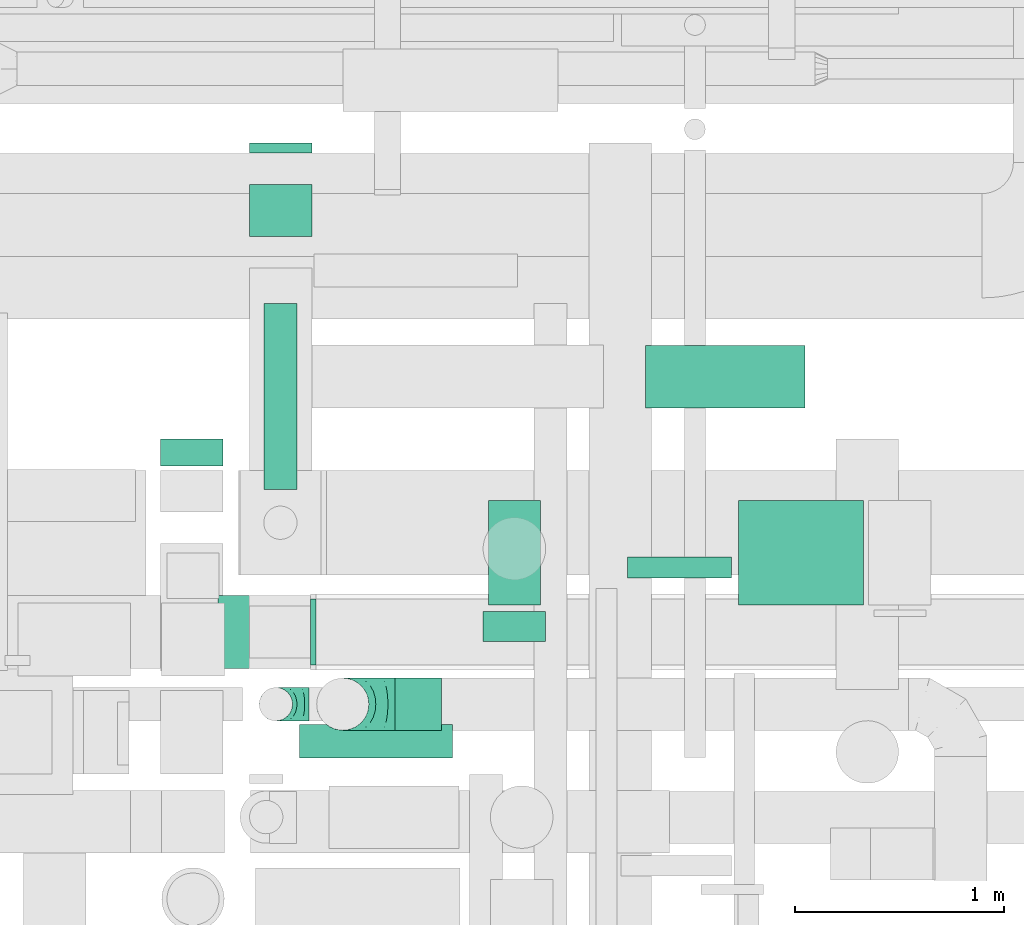
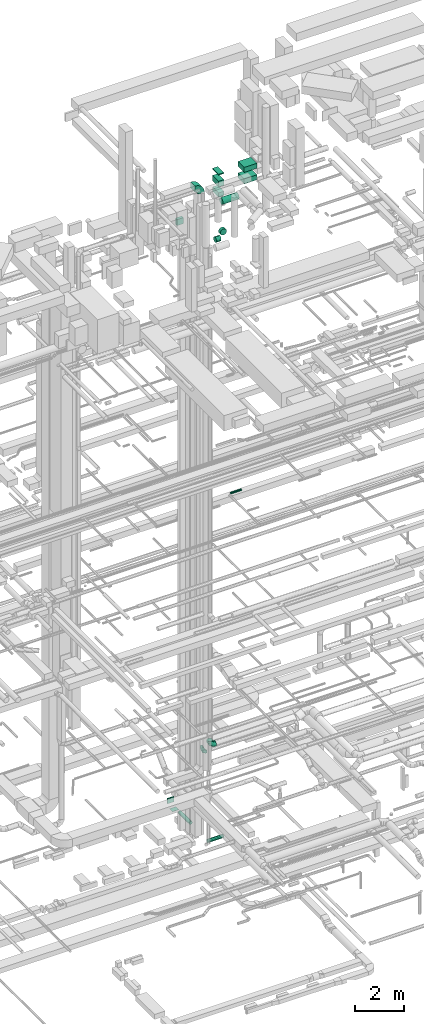
# One storey, part 146 of 337: 14 flow segments, 4 flow fittings.
"""IFC2X3 building model written with IfcOpenShell, lengths in millimetres."""

from ifc_helpers import new_model, entity, si_unit, converted_unit, derived_unit, direction, frame, frame_2d, origin, origin_2d_with_axis, place, context, subcontext, project, spatial, polyline, circle_curve, parameter, trimmed, segment, composite_curve, rectangle, circle, outline, extrude, faceted_brep, source, transform, mapped, material, type_object, type_shapes, element, save


model = new_model("IFC2X3")

# Units and contexts
model_context = context("Model", 3, precision=0.01, world=origin(), true_north=direction((6.12303176911189e-17, 1.0)))
body_context = subcontext(model_context, "Body", "Model", "MODEL_VIEW")
ifc_project = project(units=[si_unit("LENGTHUNIT", "METRE", prefix="MILLI"), si_unit("AREAUNIT", "SQUARE_METRE"), si_unit("VOLUMEUNIT", "CUBIC_METRE"), converted_unit("PLANEANGLEUNIT", "DEGREE", entity("IfcRatioMeasure", 0.0174532925199433), si_unit("PLANEANGLEUNIT", "RADIAN"), dimensions=[0, 0, 0, 0, 0, 0, 0]), si_unit("MASSUNIT", "GRAM", prefix="KILO"), derived_unit("MASSDENSITYUNIT", [(si_unit("MASSUNIT", "GRAM", prefix="KILO"), 1), (si_unit("LENGTHUNIT", "METRE"), -3)]), derived_unit("MOMENTOFINERTIAUNIT", [(si_unit("LENGTHUNIT", "METRE"), 4)]), si_unit("TIMEUNIT", "SECOND"), si_unit("FREQUENCYUNIT", "HERTZ"), si_unit("THERMODYNAMICTEMPERATUREUNIT", "DEGREE_CELSIUS"), derived_unit("THERMALTRANSMITTANCEUNIT", [(si_unit("MASSUNIT", "GRAM", prefix="KILO"), 1), (si_unit("THERMODYNAMICTEMPERATUREUNIT", "KELVIN"), -1), (si_unit("TIMEUNIT", "SECOND"), -3)]), derived_unit("VOLUMETRICFLOWRATEUNIT", [(si_unit("LENGTHUNIT", "METRE"), 3), (si_unit("TIMEUNIT", "SECOND"), -1)]), derived_unit("MASSFLOWRATEUNIT", [(si_unit("MASSUNIT", "GRAM", prefix="KILO"), 1), (si_unit("TIMEUNIT", "SECOND"), -1)]), derived_unit("ROTATIONALFREQUENCYUNIT", [(si_unit("TIMEUNIT", "SECOND"), -1)]), si_unit("ELECTRICCURRENTUNIT", "AMPERE"), si_unit("ELECTRICVOLTAGEUNIT", "VOLT"), si_unit("POWERUNIT", "WATT"), si_unit("FORCEUNIT", "NEWTON", prefix="KILO"), si_unit("ILLUMINANCEUNIT", "LUX"), si_unit("LUMINOUSFLUXUNIT", "LUMEN"), si_unit("LUMINOUSINTENSITYUNIT", "CANDELA"), derived_unit("USERDEFINED", [(si_unit("MASSUNIT", "GRAM", prefix="KILO"), -1), (si_unit("LENGTHUNIT", "METRE"), -2), (si_unit("TIMEUNIT", "SECOND"), 3), (si_unit("LUMINOUSFLUXUNIT", "LUMEN"), 1)]), derived_unit("LINEARVELOCITYUNIT", [(si_unit("LENGTHUNIT", "METRE"), 1), (si_unit("TIMEUNIT", "SECOND"), -1)]), si_unit("PRESSUREUNIT", "PASCAL"), derived_unit("USERDEFINED", [(si_unit("LENGTHUNIT", "METRE"), -2), (si_unit("MASSUNIT", "GRAM", prefix="KILO"), 1), (si_unit("TIMEUNIT", "SECOND"), -2)]), derived_unit("LINEARFORCEUNIT", [(si_unit("MASSUNIT", "GRAM", prefix="KILO"), 1), (si_unit("LENGTHUNIT", "METRE"), 1), (si_unit("TIMEUNIT", "SECOND"), -2), (si_unit("LENGTHUNIT", "METRE"), -1)]), derived_unit("PLANARFORCEUNIT", [(si_unit("MASSUNIT", "GRAM", prefix="KILO"), 1), (si_unit("LENGTHUNIT", "METRE"), 1), (si_unit("TIMEUNIT", "SECOND"), -2), (si_unit("LENGTHUNIT", "METRE"), -2)])], contexts=[model_context])

# Site, building, storey
site_placement = place(None, origin())
site = spatial("IfcSite", under=ifc_project, at=site_placement, CompositionType="ELEMENT")
building_placement = place(site_placement, origin())
building = spatial("IfcBuilding", under=site, at=building_placement, CompositionType="ELEMENT")
storey_placement = place(building_placement, origin())
storey = spatial("IfcBuildingStorey", under=building, at=storey_placement, CompositionType="ELEMENT", Elevation=0.0)

# Flow segments
duct_segment_type_1 = type_object("IfcDuctSegmentType", PredefinedType="NOTDEFINED")
flow_segment_1_placement = place(storey_placement, frame((31410.22, 14819.99, -725.0)))
element("IfcFlowSegment", 1, at=flow_segment_1_placement, inside=storey, type_object=duct_segment_type_1, context=body_context, shape_type="SweptSolid", body=[
    extrude(rectangle(XDim=49.1921251237158, YDim=300.000000000001, at=origin_2d_with_axis()), frame((150.0, 24.6, 0.0), z_axis=(0.0, 0.0, 1.0), x_axis=(0.0, 1.0, 0.0)), (0.0, 0.0, 1.0), 250.0),
])
flow_segment_2_placement = place(storey_placement, frame((31410.22, 14419.99, -885.0)))
element("IfcFlowSegment", 2, at=flow_segment_2_placement, inside=storey, type_object=duct_segment_type_1, context=body_context, shape_type="SweptSolid", body=[
    extrude(rectangle(XDim=249.999999999999, YDim=300.000000000001, at=origin_2d_with_axis()), frame((150.0, 125.0, 0.0), z_axis=(0.0, 0.0, 1.0), x_axis=(0.0, 1.0, 0.0)), (0.0, 0.0, 1.0), 9.99998998234789),
])
duct_segment_type_2 = type_object("IfcDuctSegmentType", PredefinedType="NOTDEFINED")
flow_segment_3_placement = place(storey_placement, frame((31477.32, 13208.57, -831.6)))
element("IfcFlowSegment", 3, at=flow_segment_3_placement, inside=storey, type_object=duct_segment_type_2, context=body_context, shape_type="SweptSolid", body=[
    extrude(circle(Radius=80.0, at=origin_2d_with_axis()), frame((81.6, 0.0, 81.6), z_axis=(0.0, 1.0, 0.0), x_axis=(1.0, 0.0, 0.0)), (0.0, 0.0, 1.0), 889.859270000006),
])
flow_segment_4_placement = place(storey_placement, frame((31650.77, 11919.82, -1031.6)))
element("IfcFlowSegment", 4, at=flow_segment_4_placement, inside=storey, type_object=duct_segment_type_2, context=body_context, shape_type="SweptSolid", body=[
    extrude(circle(Radius=80.0, at=origin_2d_with_axis()), frame((0.0, 81.6, 81.6), z_axis=(1.0, 0.0, 0.0), x_axis=(0.0, -1.0, 0.0)), (0.0, 0.0, 1.0), 733.340046518348),
])
flow_segment_5_placement = place(storey_placement, frame((33222.17, 12782.72, 15248.4)))
element("IfcFlowSegment", 5, at=flow_segment_5_placement, inside=storey, type_object=duct_segment_type_2, context=body_context, shape_type="SweptSolid", body=[
    extrude(circle(Radius=50.0, at=origin_2d_with_axis()), frame((0.0, 51.6, 51.6), z_axis=(1.0, 0.0, 0.0), x_axis=(0.0, -1.0, 0.0)), (0.0, 0.0, 1.0), 500.000000000051),
])
duct_segment_type_3 = type_object("IfcDuctSegmentType", PredefinedType="NOTDEFINED")
flow_segment_6_placement = place(storey_placement, frame((33309.02, 13598.0, 29093.18)))
element("IfcFlowSegment", 6, at=flow_segment_6_placement, inside=storey, type_object=duct_segment_type_3, context=body_context, shape_type="SweptSolid", body=[
    extrude(circle(Radius=150.0, at=origin_2d_with_axis()), frame((0.0, 151.6, 151.6), z_axis=(1.0, 0.0, 0.0), x_axis=(0.0, -1.0, 0.0)), (0.0, 0.0, 1.0), 763.753386249913),
])
flow_segment_7_placement = place(storey_placement, frame((32107.99, 12052.06, 28573.4)))
element("IfcFlowSegment", 7, at=flow_segment_7_placement, inside=storey, type_object=duct_segment_type_3, context=body_context, shape_type="SweptSolid", body=[
    extrude(circle(Radius=125.0, at=origin_2d_with_axis()), frame((0.0, 126.6, 126.6), z_axis=(1.0, 0.0, 0.0), x_axis=(0.0, -1.0, 0.0)), (0.0, 0.0, 1.0), 222.832411557249),
])
flow_segment_8_placement = place(storey_placement, frame((32529.23, 12478.65, 28548.4)))
element("IfcFlowSegment", 8, at=flow_segment_8_placement, inside=storey, type_object=duct_segment_type_3, context=body_context, shape_type="SweptSolid", body=[
    extrude(circle(Radius=150.0, at=origin_2d_with_axis()), frame((151.6, 0.0, 151.6), z_axis=(0.0, 1.0, 0.0), x_axis=(1.0, 0.0, 0.0)), (0.0, 0.0, 1.0), 145.442062580682),
])
duct_segment_type_4 = type_object("IfcDuctSegmentType", PredefinedType="NOTDEFINED")
flow_segment_9_placement = place(storey_placement, frame((30984.49, 13319.88, 29094.78)))
element("IfcFlowSegment", 9, at=flow_segment_9_placement, inside=storey, type_object=duct_segment_type_4, context=body_context, shape_type="SweptSolid", body=[
    extrude(rectangle(XDim=129.713805000068, YDim=300.000000000001, at=origin_2d_with_axis()), frame((150.0, 64.86, 0.0), z_axis=(0.0, 0.0, 1.0), x_axis=(0.0, 1.0, 0.0)), (0.0, 0.0, 1.0), 300.000000000001),
])
duct_segment_type_5 = type_object("IfcDuctSegmentType", PredefinedType="NOTDEFINED")
flow_segment_10_placement = place(storey_placement, frame((32555.82, 12654.98, 31450.0)))
element("IfcFlowSegment", 10, at=flow_segment_10_placement, inside=storey, type_object=duct_segment_type_5, context=body_context, shape_type="SweptSolid", body=[
    extrude(rectangle(XDim=499.999999999999, YDim=249.999999999999, at=origin_2d_with_axis()), frame((125.0, 250.0, 0.0), z_axis=(0.0, 0.0, 1.0), x_axis=(0.0, 1.0, 0.0)), (0.0, 0.0, 1.0), 49.9999750000128),
])
flow_segment_11_placement = place(storey_placement, frame((33755.82, 12654.98, 31175.0)))
element("IfcFlowSegment", 11, at=flow_segment_11_placement, inside=storey, type_object=duct_segment_type_5, context=body_context, shape_type="SweptSolid", body=[
    extrude(rectangle(XDim=598.209009999924, YDim=500.000000000001, at=origin_2d_with_axis()), frame((299.1, 250.0, 0.0)), (0.0, 0.0, 1.0), 250.000000000004),
])
flow_segment_12_placement = place(storey_placement, frame((32555.82, 12654.98, 30364.78)))
element("IfcFlowSegment", 12, at=flow_segment_12_placement, inside=storey, type_object=duct_segment_type_5, context=body_context, shape_type="SweptSolid", body=[
    extrude(rectangle(XDim=499.999999999999, YDim=249.999999999999, at=origin_2d_with_axis()), frame((125.0, 250.0, 0.0), z_axis=(0.0, 0.0, 1.0), x_axis=(0.0, -1.0, 0.0)), (0.0, 0.0, 1.0), 210.223754673466),
])
flow_segment_13_placement = place(storey_placement, frame((32555.82, 12654.98, 30875.0)))
element("IfcFlowSegment", 13, at=flow_segment_13_placement, inside=storey, type_object=duct_segment_type_5, context=body_context, shape_type="SweptSolid", body=[
    extrude(rectangle(XDim=499.999999999999, YDim=249.999999999999, at=origin_2d_with_axis()), frame((125.0, 250.0, 0.0), z_axis=(0.0, 0.0, 1.0), x_axis=(0.0, 1.0, 0.0)), (0.0, 0.0, 1.0), 275.000025),
])
flow_segment_14_placement = place(storey_placement, frame((33755.82, 12654.98, 30600.0)))
element("IfcFlowSegment", 14, at=flow_segment_14_placement, inside=storey, type_object=duct_segment_type_5, context=body_context, shape_type="SweptSolid", body=[
    extrude(rectangle(XDim=598.209009999898, YDim=500.000000000001, at=origin_2d_with_axis()), frame((299.1, 250.0, 0.0)), (0.0, 0.0, 1.0), 250.000000000004),
])

# Flow fittings
ifc_material = material()
duct_fitting_type_1 = type_object("IfcDuctFittingType", PredefinedType="NOTDEFINED", material=ifc_material)
shared_shape_1 = source(origin(), body_context, "Body", "Brep", [
    faceted_brep([(-160.0, 0.0, -80.0), (-160.0, -20.71, -77.27), (-160.0, -40.0, -69.28), (-160.0, -56.57, -56.57), (-160.0, -69.28, -40.0), (-160.0, -77.27, -20.71), (-160.0, -80.0, 0.0), (-160.0, -77.27, 20.71), (-160.0, -69.28, 40.0), (-160.0, -56.57, 56.57), (-160.0, -40.0, 69.28), (-160.0, -20.71, 77.27), (-160.0, 0.0, 80.0), (-160.0, 20.71, 77.27), (-160.0, 40.0, 69.28), (-160.0, 56.57, 56.57), (-160.0, 69.28, 40.0), (-160.0, 77.27, 20.71), (-160.0, 80.0, 0.0), (-160.0, 77.27, -20.71), (-160.0, 69.28, -40.0), (-160.0, 56.57, -56.57), (-160.0, 40.0, -69.28), (-160.0, 20.71, -77.27), (-122.68, 20.71, 77.27), (-127.85, 40.0, 69.28), (-117.13, 0.0, 80.0), (-132.29, 56.57, 56.57), (-137.83, 77.27, 20.71), (-138.56, 80.0, 0.0), (-135.69, 69.28, 40.0), (-135.69, 69.28, -40.0), (-132.29, 56.57, -56.57), (-137.83, 77.27, -20.71), (-122.68, 20.71, -77.27), (-117.13, 0.0, -80.0), (-127.85, 40.0, -69.28), (-111.58, -20.71, -77.27), (-106.41, -40.0, -69.28), (-101.97, -56.57, -56.57), (-98.56, -69.28, -40.0), (-96.42, -77.27, -20.71), (-95.69, -80.0, 0.0), (-96.42, -77.27, 20.71), (-98.56, -69.28, 40.0), (-101.97, -56.57, 56.57), (-106.41, -40.0, 69.28), (-111.58, -20.71, 77.27), (-58.03, 58.03, 77.27), (-72.15, 72.15, 69.28), (-42.87, 42.87, 80.0), (-84.28, 84.28, 56.57), (-93.59, 93.59, 40.0), (-99.44, 99.44, 20.71), (-101.44, 101.44, 0.0), (-99.44, 99.44, -20.71), (-93.59, 93.59, -40.0), (-84.28, 84.28, -56.57), (-58.03, 58.03, -77.27), (-42.87, 42.87, -80.0), (-72.15, 72.15, -69.28), (-27.71, 27.71, -77.27), (-13.59, 13.59, -69.28), (-1.46, 1.46, -56.57), (7.85, -7.85, -40.0), (13.7, -13.7, -20.71), (15.69, -15.69, 0.0), (13.7, -13.7, 20.71), (7.85, -7.85, 40.0), (-1.46, 1.46, 56.57), (-13.59, 13.59, 69.28), (-27.71, 27.71, 77.27), (-20.71, 122.68, 77.27), (-40.0, 127.85, 69.28), (0.0, 117.13, 80.0), (-56.57, 132.29, 56.57), (-69.28, 135.69, 40.0), (-77.27, 137.83, 20.71), (-80.0, 138.56, 0.0), (-77.27, 137.83, -20.71), (-69.28, 135.69, -40.0), (-56.57, 132.29, -56.57), (-20.71, 122.68, -77.27), (0.0, 117.13, -80.0), (-40.0, 127.85, -69.28), (20.71, 111.58, -77.27), (40.0, 106.41, -69.28), (56.57, 101.97, -56.57), (69.28, 98.56, -40.0), (77.27, 96.42, -20.71), (80.0, 95.69, 0.0), (77.27, 96.42, 20.71), (69.28, 98.56, 40.0), (56.57, 101.97, 56.57), (40.0, 106.41, 69.28), (20.71, 111.58, 77.27), (-20.71, 160.0, -77.27), (-40.0, 160.0, -69.28), (-56.57, 160.0, -56.57), (-69.28, 160.0, -40.0), (-77.27, 160.0, -20.71), (-80.0, 160.0, 0.0), (-77.27, 160.0, 20.71), (-69.28, 160.0, 40.0), (-56.57, 160.0, 56.57), (-40.0, 160.0, 69.28), (-20.71, 160.0, 77.27), (0.0, 160.0, 80.0), (20.71, 160.0, 77.27), (40.0, 160.0, 69.28), (56.57, 160.0, 56.57), (69.28, 160.0, 40.0), (77.27, 160.0, 20.71), (80.0, 160.0, 0.0), (77.27, 160.0, -20.71), (69.28, 160.0, -40.0), (56.57, 160.0, -56.57), (40.0, 160.0, -69.28), (20.71, 160.0, -77.27), (0.0, 160.0, -80.0)], [[[0, 1, 2, 3, 4, 5, 6, 7, 8, 9, 10, 11, 12, 13, 14, 15, 16, 17, 18, 19, 20, 21, 22, 23]], [[24, 25, 14, 13]], [[26, 24, 13, 12]], [[14, 25, 27, 15]], [[28, 29, 18, 17]], [[30, 28, 17, 16]], [[15, 27, 30, 16]], [[20, 31, 32, 21]], [[33, 31, 20, 19]], [[18, 29, 33, 19]], [[34, 35, 0, 23]], [[36, 34, 23, 22]], [[32, 36, 22, 21]], [[1, 0, 35, 37]], [[2, 1, 37, 38]], [[3, 2, 38, 39]], [[5, 4, 40, 41]], [[6, 5, 41, 42]], [[39, 40, 4, 3]], [[6, 42, 43, 7]], [[7, 43, 44, 8]], [[8, 44, 45, 9]], [[9, 45, 46, 10]], [[10, 46, 47, 11]], [[26, 12, 11, 47]], [[48, 49, 25, 24]], [[50, 48, 24, 26]], [[27, 25, 49, 51]], [[52, 53, 28, 30]], [[51, 52, 30, 27]], [[29, 28, 53, 54]], [[55, 56, 31, 33]], [[54, 55, 33, 29]], [[32, 31, 56, 57]], [[58, 59, 35, 34]], [[60, 58, 34, 36]], [[57, 60, 36, 32]], [[37, 35, 59, 61]], [[38, 37, 61, 62]], [[39, 38, 62, 63]], [[41, 40, 64, 65]], [[42, 41, 65, 66]], [[63, 64, 40, 39]], [[43, 42, 66, 67]], [[44, 43, 67, 68]], [[68, 69, 45, 44]], [[46, 45, 69, 70]], [[47, 46, 70, 71]], [[26, 47, 71, 50]], [[72, 73, 49, 48]], [[74, 72, 48, 50]], [[51, 49, 73, 75]], [[76, 77, 53, 52]], [[75, 76, 52, 51]], [[54, 53, 77, 78]], [[79, 80, 56, 55]], [[78, 79, 55, 54]], [[57, 56, 80, 81]], [[82, 83, 59, 58]], [[84, 82, 58, 60]], [[81, 84, 60, 57]], [[61, 59, 83, 85]], [[62, 61, 85, 86]], [[63, 62, 86, 87]], [[65, 64, 88, 89]], [[66, 65, 89, 90]], [[87, 88, 64, 63]], [[67, 66, 90, 91]], [[68, 67, 91, 92]], [[92, 93, 69, 68]], [[70, 69, 93, 94]], [[71, 70, 94, 95]], [[50, 71, 95, 74]], [[96, 97, 98, 99, 100, 101, 102, 103, 104, 105, 106, 107, 108, 109, 110, 111, 112, 113, 114, 115, 116, 117, 118, 119]], [[72, 74, 107, 106]], [[73, 72, 106, 105]], [[75, 73, 105, 104]], [[77, 76, 103, 102]], [[78, 77, 102, 101]], [[75, 104, 103, 76]], [[78, 101, 100, 79]], [[79, 100, 99, 80]], [[80, 99, 98, 81]], [[84, 97, 96, 82]], [[82, 96, 119, 83]], [[84, 81, 98, 97]], [[118, 117, 86, 85]], [[119, 118, 85, 83]], [[116, 87, 86, 117]], [[88, 115, 114, 89]], [[89, 114, 113, 90]], [[115, 88, 87, 116]], [[112, 111, 92, 91]], [[113, 112, 91, 90]], [[111, 110, 93, 92]], [[95, 94, 109, 108]], [[74, 95, 108, 107]], [[110, 109, 94, 93]]]),
])
type_shapes(duct_fitting_type_1, [shared_shape_1])
flow_fitting_1_placement = place(storey_placement, frame((31537.12, 12178.65, 3400.0), z_axis=(0.0, 1.0, 0.0), x_axis=(-1.0, 0.0, 0.0)))
element("IfcFlowFitting", 15, at=flow_fitting_1_placement, inside=storey, type_object=duct_fitting_type_1, material=ifc_material, context=body_context, shape_type="MappedRepresentation", body=[
    mapped(shared_shape_1, transform((0.0, 0.0, 0.0), scale=1.0)),
])
duct_fitting_type_2 = type_object("IfcDuctFittingType", PredefinedType="NOTDEFINED", material=ifc_material)
shared_shape_2 = source(origin(), body_context, "Body", "Brep", [
    faceted_brep([(-250.0, 0.0, -125.0), (-250.0, -32.35, -120.74), (-250.0, -62.5, -108.25), (-250.0, -88.39, -88.39), (-250.0, -108.25, -62.5), (-250.0, -120.74, -32.35), (-250.0, -125.0, 0.0), (-250.0, -120.74, 32.35), (-250.0, -108.25, 62.5), (-250.0, -88.39, 88.39), (-250.0, -62.5, 108.25), (-250.0, -32.35, 120.74), (-250.0, 0.0, 125.0), (-250.0, 32.35, 120.74), (-250.0, 62.5, 108.25), (-250.0, 88.39, 88.39), (-250.0, 108.25, 62.5), (-250.0, 120.74, 32.35), (-250.0, 125.0, 0.0), (-250.0, 120.74, -32.35), (-250.0, 108.25, -62.5), (-250.0, 88.39, -88.39), (-250.0, 62.5, -108.25), (-250.0, 32.35, -120.74), (-191.68, 32.35, 120.74), (-199.76, 62.5, 108.25), (-183.01, 0.0, 125.0), (-206.7, 88.39, 88.39), (-215.37, 120.74, 32.35), (-216.51, 125.0, 0.0), (-212.02, 108.25, 62.5), (-212.02, 108.25, -62.5), (-206.7, 88.39, -88.39), (-215.37, 120.74, -32.35), (-191.68, 32.35, -120.74), (-183.01, 0.0, -125.0), (-199.76, 62.5, -108.25), (-174.34, -32.35, -120.74), (-166.27, -62.5, -108.25), (-159.33, -88.39, -88.39), (-154.01, -108.25, -62.5), (-150.66, -120.74, -32.35), (-149.52, -125.0, 0.0), (-150.66, -120.74, 32.35), (-154.01, -108.25, 62.5), (-159.33, -88.39, 88.39), (-166.27, -62.5, 108.25), (-174.34, -32.35, 120.74), (-90.67, 90.67, 120.74), (-112.74, 112.74, 108.25), (-66.99, 66.99, 125.0), (-131.69, 131.69, 88.39), (-146.23, 146.23, 62.5), (-155.38, 155.38, 32.35), (-158.49, 158.49, 0.0), (-155.38, 155.38, -32.35), (-146.23, 146.23, -62.5), (-131.69, 131.69, -88.39), (-90.67, 90.67, -120.74), (-66.99, 66.99, -125.0), (-112.74, 112.74, -108.25), (-43.3, 43.3, -120.74), (-21.23, 21.23, -108.25), (-2.28, 2.28, -88.39), (12.26, -12.26, -62.5), (21.4, -21.4, -32.35), (24.52, -24.52, 0.0), (21.4, -21.4, 32.35), (12.26, -12.26, 62.5), (-2.28, 2.28, 88.39), (-21.23, 21.23, 108.25), (-43.3, 43.3, 120.74), (-32.35, 191.68, 120.74), (-62.5, 199.76, 108.25), (0.0, 183.01, 125.0), (-88.39, 206.7, 88.39), (-108.25, 212.02, 62.5), (-120.74, 215.37, 32.35), (-125.0, 216.51, 0.0), (-120.74, 215.37, -32.35), (-108.25, 212.02, -62.5), (-88.39, 206.7, -88.39), (-32.35, 191.68, -120.74), (0.0, 183.01, -125.0), (-62.5, 199.76, -108.25), (32.35, 174.34, -120.74), (62.5, 166.27, -108.25), (88.39, 159.33, -88.39), (108.25, 154.01, -62.5), (120.74, 150.66, -32.35), (125.0, 149.52, 0.0), (120.74, 150.66, 32.35), (108.25, 154.01, 62.5), (88.39, 159.33, 88.39), (62.5, 166.27, 108.25), (32.35, 174.34, 120.74), (-32.35, 250.0, -120.74), (-62.5, 250.0, -108.25), (-88.39, 250.0, -88.39), (-108.25, 250.0, -62.5), (-120.74, 250.0, -32.35), (-125.0, 250.0, 0.0), (-120.74, 250.0, 32.35), (-108.25, 250.0, 62.5), (-88.39, 250.0, 88.39), (-62.5, 250.0, 108.25), (-32.35, 250.0, 120.74), (0.0, 250.0, 125.0), (32.35, 250.0, 120.74), (62.5, 250.0, 108.25), (88.39, 250.0, 88.39), (108.25, 250.0, 62.5), (120.74, 250.0, 32.35), (125.0, 250.0, 0.0), (120.74, 250.0, -32.35), (108.25, 250.0, -62.5), (88.39, 250.0, -88.39), (62.5, 250.0, -108.25), (32.35, 250.0, -120.74), (0.0, 250.0, -125.0)], [[[0, 1, 2, 3, 4, 5, 6, 7, 8, 9, 10, 11, 12, 13, 14, 15, 16, 17, 18, 19, 20, 21, 22, 23]], [[24, 25, 14, 13]], [[26, 24, 13, 12]], [[14, 25, 27, 15]], [[28, 29, 18, 17]], [[30, 28, 17, 16]], [[15, 27, 30, 16]], [[20, 31, 32, 21]], [[33, 31, 20, 19]], [[18, 29, 33, 19]], [[34, 35, 0, 23]], [[36, 34, 23, 22]], [[21, 32, 36, 22]], [[1, 0, 35, 37]], [[2, 1, 37, 38]], [[38, 39, 3, 2]], [[5, 4, 40, 41]], [[6, 5, 41, 42]], [[39, 40, 4, 3]], [[6, 42, 43, 7]], [[7, 43, 44, 8]], [[8, 44, 45, 9]], [[9, 45, 46, 10]], [[10, 46, 47, 11]], [[26, 12, 11, 47]], [[48, 49, 25, 24]], [[50, 48, 24, 26]], [[27, 25, 49, 51]], [[52, 53, 28, 30]], [[51, 52, 30, 27]], [[29, 28, 53, 54]], [[55, 56, 31, 33]], [[54, 55, 33, 29]], [[32, 31, 56, 57]], [[58, 59, 35, 34]], [[60, 58, 34, 36]], [[57, 60, 36, 32]], [[37, 35, 59, 61]], [[38, 37, 61, 62]], [[39, 38, 62, 63]], [[41, 40, 64, 65]], [[42, 41, 65, 66]], [[63, 64, 40, 39]], [[43, 42, 66, 67]], [[44, 43, 67, 68]], [[68, 69, 45, 44]], [[46, 45, 69, 70]], [[47, 46, 70, 71]], [[26, 47, 71, 50]], [[72, 73, 49, 48]], [[74, 72, 48, 50]], [[51, 49, 73, 75]], [[76, 77, 53, 52]], [[75, 76, 52, 51]], [[54, 53, 77, 78]], [[79, 80, 56, 55]], [[78, 79, 55, 54]], [[57, 56, 80, 81]], [[82, 83, 59, 58]], [[84, 82, 58, 60]], [[81, 84, 60, 57]], [[61, 59, 83, 85]], [[62, 61, 85, 86]], [[63, 62, 86, 87]], [[65, 64, 88, 89]], [[66, 65, 89, 90]], [[87, 88, 64, 63]], [[67, 66, 90, 91]], [[68, 67, 91, 92]], [[92, 93, 69, 68]], [[70, 69, 93, 94]], [[71, 70, 94, 95]], [[50, 71, 95, 74]], [[96, 97, 98, 99, 100, 101, 102, 103, 104, 105, 106, 107, 108, 109, 110, 111, 112, 113, 114, 115, 116, 117, 118, 119]], [[72, 74, 107, 106]], [[73, 72, 106, 105]], [[75, 73, 105, 104]], [[77, 76, 103, 102]], [[78, 77, 102, 101]], [[75, 104, 103, 76]], [[78, 101, 100, 79]], [[79, 100, 99, 80]], [[80, 99, 98, 81]], [[84, 97, 96, 82]], [[82, 96, 119, 83]], [[84, 81, 98, 97]], [[83, 119, 118, 85]], [[85, 118, 117, 86]], [[116, 87, 86, 117]], [[88, 115, 114, 89]], [[89, 114, 113, 90]], [[115, 88, 87, 116]], [[91, 90, 113, 112]], [[92, 91, 112, 111]], [[111, 110, 93, 92]], [[95, 94, 109, 108]], [[74, 95, 108, 107]], [[110, 109, 94, 93]]]),
])
type_shapes(duct_fitting_type_2, [shared_shape_2])
flow_fitting_2_placement = place(storey_placement, frame((31857.99, 12178.65, 3650.0), z_axis=(0.0, 1.0, 0.0), x_axis=(-1.0, 0.0, 0.0)))
element("IfcFlowFitting", 16, at=flow_fitting_2_placement, inside=storey, type_object=duct_fitting_type_2, material=ifc_material, context=body_context, shape_type="MappedRepresentation", body=[
    mapped(shared_shape_2, transform((0.0, 0.0, 0.0), scale=1.0)),
])
duct_fitting_type_3 = type_object("IfcDuctFittingType", PredefinedType="NOTDEFINED", material=ifc_material)
shared_shape_3 = source(origin(), body_context, "Body", "Brep", [
    faceted_brep([(20.0, 40.76, -152.13), (20.0, 78.75, -136.4), (20.0, 111.37, -111.37), (20.0, 136.4, -78.75), (20.0, 152.13, -40.76), (20.0, 157.5, 0.0), (20.0, 152.13, 40.76), (20.0, 136.4, 78.75), (20.0, 111.37, 111.37), (20.0, 78.75, 136.4), (20.0, 40.76, 152.13), (20.0, 0.0, 157.5), (20.0, -40.76, 152.13), (20.0, -78.75, 136.4), (20.0, -111.37, 111.37), (20.0, -136.4, 78.75), (20.0, -152.13, 40.76), (20.0, -157.5, 0.0), (20.0, -152.13, -40.76), (20.0, -136.4, -78.75), (20.0, -111.37, -111.37), (20.0, -78.75, -136.4), (20.0, -40.76, -152.13), (20.0, 0.0, -157.5), (0.0, 0.0, 157.5), (0.0, 40.76, 152.13), (-6.1, 40.76, 152.13), (-6.1, 0.0, 157.5), (0.0, 78.75, 136.4), (-6.1, 78.75, 136.4), (0.0, 111.37, 111.37), (-6.1, 111.37, 111.37), (0.0, 136.4, 78.75), (0.0, 152.13, 40.76), (-6.1, 152.13, 40.76), (-6.1, 136.4, 78.75), (0.0, 157.5, 0.0), (-6.1, 157.5, 0.0), (0.0, 152.13, -40.76), (-6.1, 152.13, -40.76), (0.0, 136.4, -78.75), (-6.1, 136.4, -78.75), (0.0, 111.37, -111.37), (-6.1, 111.37, -111.37), (0.0, 0.0, -157.5), (-6.1, 0.0, -157.5), (-6.1, 40.76, -152.13), (0.0, 40.76, -152.13), (-6.1, 78.75, -136.4), (0.0, 78.75, -136.4), (0.0, -40.76, -152.13), (-6.1, -40.76, -152.13), (0.0, -78.75, -136.4), (-6.1, -78.75, -136.4), (0.0, -111.37, -111.37), (-6.1, -111.37, -111.37), (0.0, -136.4, -78.75), (0.0, -152.13, -40.76), (-6.1, -152.13, -40.76), (-6.1, -136.4, -78.75), (0.0, -157.5, 0.0), (-6.1, -157.5, 0.0), (0.0, -152.13, 40.76), (-6.1, -152.13, 40.76), (0.0, -136.4, 78.75), (-6.1, -136.4, 78.75), (0.0, -111.37, 111.37), (-6.1, -111.37, 111.37), (0.0, -78.75, 136.4), (0.0, -40.76, 152.13), (-6.1, -40.76, 152.13), (-6.1, -78.75, 136.4)], [[[0, 1, 2, 3, 4, 5, 6, 7, 8, 9, 10, 11, 12, 13, 14, 15, 16, 17, 18, 19, 20, 21, 22, 23]], [[24, 11, 10, 25, 26, 27]], [[25, 10, 9, 28, 29, 26]], [[28, 9, 8, 30, 31, 29]], [[32, 7, 6, 33, 34, 35]], [[33, 6, 5, 36, 37, 34]], [[30, 8, 7, 32, 35, 31]], [[36, 5, 4, 38, 39, 37]], [[38, 4, 3, 40, 41, 39]], [[40, 3, 2, 42, 43, 41]], [[0, 23, 44, 45, 46, 47]], [[1, 0, 47, 46, 48, 49]], [[49, 48, 43, 42, 2, 1]], [[44, 23, 22, 50, 51, 45]], [[50, 22, 21, 52, 53, 51]], [[52, 21, 20, 54, 55, 53]], [[56, 19, 18, 57, 58, 59]], [[57, 18, 17, 60, 61, 58]], [[54, 20, 19, 56, 59, 55]], [[60, 17, 16, 62, 63, 61]], [[62, 16, 15, 64, 65, 63]], [[64, 15, 14, 66, 67, 65]], [[68, 13, 12, 69, 70, 71]], [[69, 12, 11, 24, 27, 70]], [[66, 14, 13, 68, 71, 67]], [[45, 51, 53, 55, 59, 58, 61, 63, 65, 67, 71, 70, 27, 26, 29, 31, 35, 34, 37, 39, 41, 43, 48, 46]]]),
])
type_shapes(duct_fitting_type_3, [shared_shape_3])
flow_fitting_3_placement = place(storey_placement, frame((31710.09, 12524.99, 3300.0), z_axis=(0.0, -1.0, 0.0), x_axis=(1.0, 0.0, 0.0)))
element("IfcFlowFitting", 17, at=flow_fitting_3_placement, inside=storey, type_object=duct_fitting_type_3, material=ifc_material, context=body_context, shape_type="MappedRepresentation", body=[
    mapped(shared_shape_3, transform((0.0, 0.0, 0.0), scale=1.0)),
])
duct_fitting_type_4 = type_object("IfcDuctFittingType", PredefinedType="NOTDEFINED", material=ifc_material)
shared_shape_4 = source(origin(), body_context, "Body", "SweptSolid", [
    extrude(outline(composite_curve([segment(polyline([(-300.0, -150.0), (0.0, -150.0)]), True, "CONTINUOUS"), segment(trimmed(circle_curve(frame_2d((150.0, -150.0), x_axis=(4.12694814144743e-06, 1.0)), 150.0), [parameter(0.0)], [parameter(90.0002364567113)], True, "PARAMETER"), False, "CONTINUOUS"), segment(polyline([(150.0, 0.0), (150.0, 300.0)]), True, "CONTINUOUS"), segment(trimmed(circle_curve(frame_2d((150.0, -150.0), x_axis=(4.12694814144743e-06, 1.0)), 450.0), [parameter(0.0)], [parameter(90.0002364567113)], True, "PARAMETER"), True, "CONTINUOUS")], self_intersect=False)), frame((-150.0, 150.0, -175.0), z_axis=(0.0, 0.0, 1.0), x_axis=(-1.0, -4.1269481496613e-06, 0.0)), (0.0, 0.0, 1.0), 350.0),
])
type_shapes(duct_fitting_type_4, [shared_shape_4])
flow_fitting_4_placement = place(storey_placement, frame((31559.27, 12524.99, 31400.0), z_axis=(0.0, -1.0, 0.0), x_axis=(4.12694815013015e-06, 0.0, 1.0)))
element("IfcFlowFitting", 18, at=flow_fitting_4_placement, inside=storey, type_object=duct_fitting_type_4, material=ifc_material, context=body_context, shape_type="MappedRepresentation", body=[
    mapped(shared_shape_4, transform((0.0, 0.0, 0.0), scale=1.0)),
])

save(model, "model.ifc")
